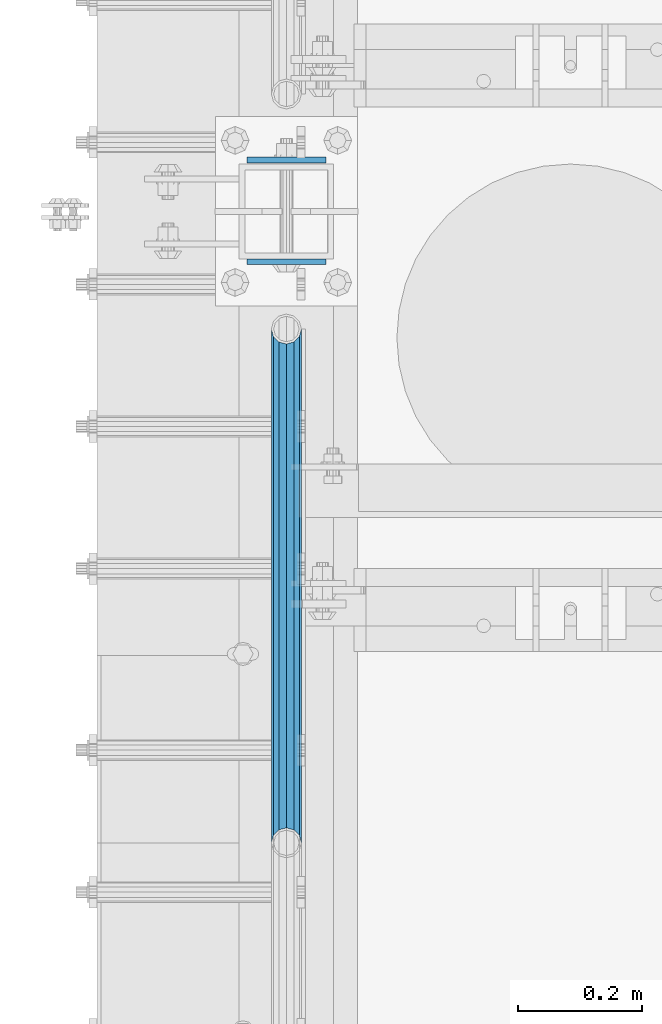
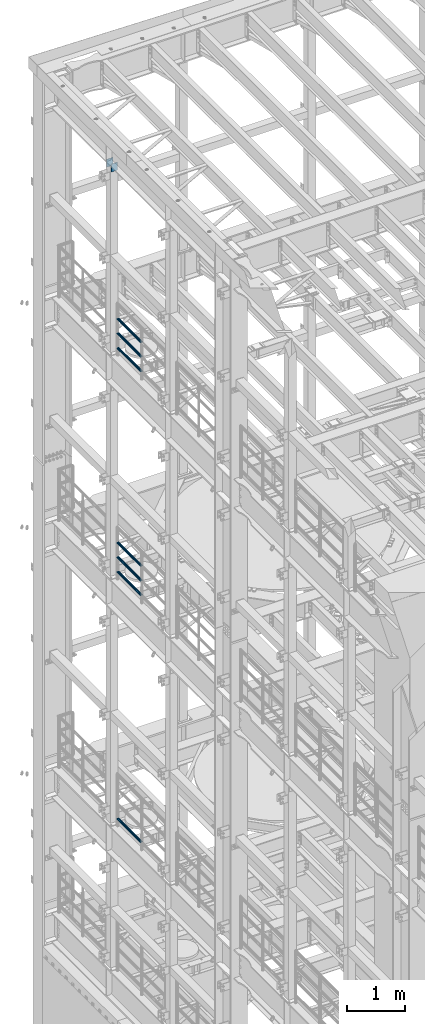
# One storey, part 1306 of 1876: 9 beams, 4 elements without a shape of their own.
"""IFC2X3 building model written with IfcOpenShell, lengths in millimetres."""

from ifc_helpers import new_model, si_unit, frame, origin_with_axes, place, context, subcontext, project, spatial, faceted_brep, material, type_object, element, aggregate, save


model = new_model("IFC2X3")

# Units and contexts
model_context = context("Model", 3, precision=1e-05, world=origin_with_axes())
body_context = subcontext(model_context, "Body", "Model", "MODEL_VIEW")
ifc_project = project(units=[si_unit("LENGTHUNIT", "METRE", prefix="MILLI"), si_unit("AREAUNIT", "SQUARE_METRE"), si_unit("VOLUMEUNIT", "CUBIC_METRE"), si_unit("MASSUNIT", "GRAM", prefix="KILO"), si_unit("TIMEUNIT", "SECOND"), si_unit("PLANEANGLEUNIT", "RADIAN"), si_unit("SOLIDANGLEUNIT", "STERADIAN"), si_unit("THERMODYNAMICTEMPERATUREUNIT", "DEGREE_CELSIUS"), si_unit("LUMINOUSINTENSITYUNIT", "LUMEN")], contexts=[model_context])

# Site, building, storey
site_placement = place(None, origin_with_axes())
site = spatial("IfcSite", under=ifc_project, at=site_placement, CompositionType="ELEMENT")
building_placement = place(site_placement, origin_with_axes())
building = spatial("IfcBuilding", under=site, at=building_placement, Name="Undefined", CompositionType="ELEMENT")
storey_placement = place(building_placement, origin_with_axes())
storey = spatial("IfcBuildingStorey", under=building, at=storey_placement, Name="Undefined", CompositionType="ELEMENT", Elevation=0.0)

# Assembly, beams
assembly_1_placement = place(storey_placement, origin_with_axes())
assembly_1 = element("IfcElementAssembly", 1, at=assembly_1_placement, inside=storey, Name="RAIL", AssemblyPlace="NOTDEFINED", PredefinedType="RIGID_FRAME")
ifc_material_1 = material()
beam_type_1 = type_object("IfcBeamType", Name="PIPE1-1/2SCH40", PredefinedType="NOTDEFINED")
beam_1_placement = place(assembly_1_placement, frame((-1.81898940354586e-12, 11494.77, 18145.125), z_axis=(0.0, 0.0, 1.0), x_axis=(0.0, -1.0, 0.0)))
beam_1 = element("IfcBeam", 2, at=beam_1_placement, type_object=beam_type_1, material=ifc_material_1, Name="RAIL", ObjectType="PIPE1-1/2SCH40", context=body_context, shape_type="Brep", body=[
    faceted_brep([(805.872807006681, -12.0649999999996, 20.8971929933177), (805.872807006683, -12.0649999999996, 15.8661214311796), (805.379378568819, -10.2235000000001, 17.7076214311819), (802.640000000001, 0.0, 20.4470000000001), (802.640000000001, 0.0, 24.130000000001), (805.379378568819, 10.2235000000001, 17.7076214311819), (805.872807006683, 12.0649999999996, 15.8661214311796), (805.872807006681, 12.0649999999996, 20.8971929933177), (826.77, 24.1300000000001, 0.0), (814.705, 20.8971929933186, 12.0649999999987), (814.705, 20.8971929933186, -12.0649999999987), (811.515428437862, 17.7076214311801, 10.2235000000001), (814.254807006682, 20.4470000000001, 0.0), (811.515428437862, 17.7076214311801, -10.2235000000001), (805.872807006683, 12.0649999999996, -15.8661214311796), (805.872807006681, 12.0649999999996, -20.8971929933177), (805.379378568819, 10.2235000000001, -17.7076214311819), (802.640000000001, 0.0, -20.4470000000001), (802.640000000001, 0.0, -24.130000000001), (805.872807006683, -12.0649999999996, -15.8661214311796), (805.872807006681, -12.0649999999996, -20.8971929933177), (805.379378568819, -10.2235000000001, -17.7076214311819), (826.77, -24.1300000000001, 0.0), (814.705, -20.8971929933186, -12.0649999999987), (814.705, -20.8971929933186, 12.0649999999987), (811.515428437862, -17.7076214311801, -10.2235000000001), (814.254807006682, -20.4470000000001, 0.0), (811.515428437862, -17.7076214311801, 10.2235000000001), (12.0650000000064, -20.8971929933177, -12.0649999999987), (20.8971929933249, -12.0650000000005, -20.8971929933177), (0.0, 24.1299999999992, 0.0), (12.0650000000064, 20.8971929933177, -12.0649999999987), (12.0650000000064, 20.8971929933177, 12.0649999999987), (20.8971929933249, 12.0650000000005, 20.8971929933177), (24.1300000000064, 0.0, 24.130000000001), (20.8971929933249, 12.0650000000005, -20.8971929933177), (24.1300000000063, 0.0, -24.130000000001), (24.1300000000063, 0.0, -20.4470000000001), (20.8971929933249, -12.0650000000005, -15.8661214311796), (21.3906214311868, -10.2235000000001, -17.7076214311819), (21.3906214311868, 10.2235000000001, -17.7076214311819), (20.8971929933249, 12.0650000000005, -15.8661214311796), (15.2545715621445, 17.7076214311801, -10.2235000000001), (12.5151929933249, 20.4470000000001, 0.0), (15.2545715621445, 17.7076214311801, 10.2235000000001), (20.8971929933249, 12.0650000000005, 15.8661214311796), (21.3906214311868, 10.2235000000001, 17.7076214311819), (24.1300000000064, 0.0, 20.4470000000001), (21.3906214311868, -10.2235000000001, 17.7076214311819), (20.8971929933249, -12.0650000000005, 15.8661214311796), (20.8971929933249, -12.0650000000005, 20.8971929933177), (12.0650000000064, -20.8971929933177, 12.0649999999987), (0.0, -24.1299999999992, 0.0), (15.2545715621445, -17.7076214311801, 10.2235000000001), (12.5151929933249, -20.4470000000001, 0.0), (15.2545715621445, -17.7076214311801, -10.2235000000001)], [[[0, 1, 2, 3, 4]], [[4, 3, 5, 6, 7]], [[8, 9, 10]], [[7, 6, 11, 12, 13, 14, 15, 10, 9]], [[16, 17, 18, 15, 14]], [[19, 20, 18, 17, 21]], [[22, 23, 24]], [[24, 23, 20, 19, 25, 26, 27, 1, 0]], [[28, 29, 20, 23]], [[30, 31, 32]], [[33, 34, 4, 7]], [[32, 33, 7, 9]], [[30, 32, 9, 8]], [[31, 30, 8, 10]], [[35, 31, 10, 15]], [[36, 35, 15, 18]], [[29, 36, 18, 20]], [[37, 36, 29, 38, 39]], [[40, 41, 35, 36, 37]], [[32, 31, 35, 41, 42, 43, 44, 45, 33]], [[33, 45, 46, 47, 34]], [[34, 47, 48, 49, 50]], [[34, 50, 0, 4]], [[50, 51, 24, 0]], [[51, 52, 22, 24]], [[52, 28, 23, 22]], [[51, 28, 52]], [[50, 49, 53, 54, 55, 38, 29, 28, 51]], [[55, 54, 26, 25]], [[21, 39, 38, 55, 25, 19]], [[37, 39, 21, 17]], [[40, 37, 17, 16]], [[42, 41, 40, 16, 14, 13]], [[43, 42, 13, 12]], [[44, 43, 12, 11]], [[5, 46, 45, 44, 11, 6]], [[47, 46, 5, 3]], [[48, 47, 3, 2]], [[53, 49, 48, 2, 1, 27]], [[54, 53, 27, 26]]]),
])
beam_2_placement = place(assembly_1_placement, frame((-1.81898940354586e-12, 10668.0, 18449.925), z_axis=(0.0, 0.0, -1.0), x_axis=(0.0, 1.0, 0.0)))
beam_2 = element("IfcBeam", 3, at=beam_2_placement, type_object=beam_type_1, material=ifc_material_1, Name="RAIL", ObjectType="PIPE1-1/2SCH40", context=body_context, shape_type="Brep", body=[
    faceted_brep([(0.0, 24.1299999999992, 0.0), (12.0650000000064, 20.8971929933177, -12.0649999999987), (12.0650000000064, 20.8971929933177, 12.0649999999987), (12.0650000000064, -20.8971929933177, 12.0649999999987), (12.0650000000064, -20.8971929933177, -12.0649999999987), (0.0, -24.1299999999992, 0.0), (20.8971929933249, -12.0650000000005, 20.8971929933177), (20.8971929933249, -12.0650000000005, 15.8661214311796), (15.2545715621445, -17.7076214311801, 10.2235000000001), (12.5151929933249, -20.4470000000001, 0.0), (15.2545715621445, -17.7076214311801, -10.2235000000001), (20.8971929933249, -12.0650000000005, -15.8661214311796), (20.8971929933249, -12.0650000000005, -20.8971929933177), (24.1300000000063, 0.0, -20.4470000000001), (24.1300000000063, 0.0, -24.130000000001), (21.3906214311868, -10.2235000000001, -17.7076214311819), (21.3906214311868, 10.2235000000001, -17.7076214311819), (20.8971929933249, 12.0650000000005, -15.8661214311796), (20.8971929933249, 12.0650000000005, -20.8971929933177), (15.2545715621445, 17.7076214311801, -10.2235000000001), (12.5151929933249, 20.4470000000001, 0.0), (15.2545715621445, 17.7076214311801, 10.2235000000001), (20.8971929933249, 12.0650000000005, 15.8661214311796), (20.8971929933249, 12.0650000000005, 20.8971929933177), (21.3906214311868, 10.2235000000001, 17.7076214311819), (24.1300000000064, 0.0, 20.4470000000001), (24.1300000000064, 0.0, 24.130000000001), (21.3906214311868, -10.2235000000001, 17.7076214311819), (826.77, 24.1300000000001, 0.0), (814.705, 20.8971929933186, -12.0649999999987), (805.872807006681, 12.0649999999996, -20.8971929933177), (826.77, -24.1300000000001, 0.0), (814.705, -20.8971929933186, -12.0649999999987), (814.705, -20.8971929933186, 12.0649999999987), (805.872807006681, -12.0649999999996, 20.8971929933177), (805.872807006681, -12.0649999999996, -20.8971929933177), (802.640000000001, 0.0, -24.130000000001), (805.379378568819, 10.2235000000001, -17.7076214311819), (802.640000000001, 0.0, -20.4470000000001), (805.872807006683, 12.0649999999996, -15.8661214311796), (805.872807006683, -12.0649999999996, -15.8661214311796), (805.379378568819, -10.2235000000001, -17.7076214311819), (811.515428437862, -17.7076214311801, -10.2235000000001), (814.254807006682, -20.4470000000001, 0.0), (811.515428437862, -17.7076214311801, 10.2235000000001), (805.872807006683, -12.0649999999996, 15.8661214311796), (805.379378568819, -10.2235000000001, 17.7076214311819), (802.640000000001, 0.0, 20.4470000000001), (802.640000000001, 0.0, 24.130000000001), (805.872807006681, 12.0649999999996, 20.8971929933177), (814.705, 20.8971929933186, 12.0649999999987), (805.872807006683, 12.0649999999996, 15.8661214311796), (811.515428437862, 17.7076214311801, 10.2235000000001), (814.254807006682, 20.4470000000001, 0.0), (811.515428437862, 17.7076214311801, -10.2235000000001), (805.379378568819, 10.2235000000001, 17.7076214311819)], [[[0, 1, 2]], [[3, 4, 5]], [[6, 7, 8, 9, 10, 11, 12, 4, 3]], [[13, 14, 12, 11, 15]], [[16, 17, 18, 14, 13]], [[2, 1, 18, 17, 19, 20, 21, 22, 23]], [[23, 22, 24, 25, 26]], [[26, 25, 27, 7, 6]], [[1, 0, 28, 29]], [[18, 1, 29, 30]], [[31, 32, 33]], [[6, 3, 33, 34]], [[3, 5, 31, 33]], [[5, 4, 32, 31]], [[4, 12, 35, 32]], [[12, 14, 36, 35]], [[14, 18, 30, 36]], [[37, 38, 36, 30, 39]], [[40, 35, 36, 38, 41]], [[33, 32, 35, 40, 42, 43, 44, 45, 34]], [[34, 45, 46, 47, 48]], [[26, 6, 34, 48]], [[2, 23, 49, 50]], [[23, 26, 48, 49]], [[0, 2, 50, 28]], [[28, 50, 29]], [[49, 51, 52, 53, 54, 39, 30, 29, 50]], [[48, 47, 55, 51, 49]], [[25, 24, 55, 47]], [[55, 24, 22, 21, 52, 51]], [[21, 20, 53, 52]], [[20, 19, 54, 53]], [[19, 17, 16, 37, 39, 54]], [[16, 13, 38, 37]], [[13, 15, 41, 38]], [[41, 15, 11, 10, 42, 40]], [[10, 9, 43, 42]], [[9, 8, 44, 43]], [[8, 7, 27, 46, 45, 44]], [[27, 25, 47, 46]]]),
])
beam_3_placement = place(assembly_1_placement, frame((-1.81898940354586e-12, 10668.0, 18754.725), z_axis=(0.0, 0.0, -1.0), x_axis=(0.0, 1.0, 0.0)))
beam_3 = element("IfcBeam", 4, at=beam_3_placement, type_object=beam_type_1, material=ifc_material_1, Name="RAIL", ObjectType="PIPE1-1/2SCH40", context=body_context, shape_type="Brep", body=[
    faceted_brep([(0.0, 24.1299999999992, 0.0), (12.0650000000064, 20.8971929933177, -12.0649999999987), (12.0650000000064, 20.8971929933177, 12.0649999999987), (12.0650000000064, -20.8971929933177, 12.0649999999987), (12.0650000000064, -20.8971929933177, -12.0649999999987), (0.0, -24.1299999999992, 0.0), (20.8971929933249, -12.0650000000005, 20.8971929933177), (20.8971929933249, -12.0650000000005, 15.8661214311796), (15.2545715621445, -17.7076214311801, 10.2235000000001), (12.5151929933249, -20.4470000000001, 0.0), (15.2545715621445, -17.7076214311801, -10.2235000000001), (20.8971929933249, -12.0650000000005, -15.8661214311796), (20.8971929933249, -12.0650000000005, -20.8971929933177), (24.1300000000063, 0.0, -20.4470000000001), (24.1300000000063, 0.0, -24.130000000001), (21.3906214311868, -10.2235000000001, -17.7076214311819), (21.3906214311868, 10.2235000000001, -17.7076214311819), (20.8971929933249, 12.0650000000005, -15.8661214311796), (20.8971929933249, 12.0650000000005, -20.8971929933177), (15.2545715621445, 17.7076214311801, -10.2235000000001), (12.5151929933249, 20.4470000000001, 0.0), (15.2545715621445, 17.7076214311801, 10.2235000000001), (20.8971929933249, 12.0650000000005, 15.8661214311796), (20.8971929933249, 12.0650000000005, 20.8971929933177), (21.3906214311868, 10.2235000000001, 17.7076214311819), (24.1300000000064, 0.0, 20.4470000000001), (24.1300000000064, 0.0, 24.130000000001), (21.3906214311868, -10.2235000000001, 17.7076214311819), (826.77, 24.1300000000001, 0.0), (814.705, 20.8971929933186, -12.0649999999987), (805.872807006681, 12.0649999999996, -20.8971929933177), (826.77, -24.1300000000001, 0.0), (814.705, -20.8971929933186, -12.0649999999987), (814.705, -20.8971929933186, 12.0649999999987), (805.872807006681, -12.0649999999996, 20.8971929933177), (805.872807006681, -12.0649999999996, -20.8971929933177), (802.640000000001, 0.0, -24.130000000001), (805.379378568819, 10.2235000000001, -17.7076214311819), (802.640000000001, 0.0, -20.4470000000001), (805.872807006683, 12.0649999999996, -15.8661214311796), (805.872807006683, -12.0649999999996, -15.8661214311796), (805.379378568819, -10.2235000000001, -17.7076214311819), (811.515428437862, -17.7076214311801, -10.2235000000001), (814.254807006682, -20.4470000000001, 0.0), (811.515428437862, -17.7076214311801, 10.2235000000001), (805.872807006683, -12.0649999999996, 15.8661214311796), (805.379378568819, -10.2235000000001, 17.7076214311819), (802.640000000001, 0.0, 20.4470000000001), (802.640000000001, 0.0, 24.130000000001), (805.872807006681, 12.0649999999996, 20.8971929933177), (814.705, 20.8971929933186, 12.0649999999987), (805.872807006683, 12.0649999999996, 15.8661214311796), (811.515428437862, 17.7076214311801, 10.2235000000001), (814.254807006682, 20.4470000000001, 0.0), (811.515428437862, 17.7076214311801, -10.2235000000001), (805.379378568819, 10.2235000000001, 17.7076214311819)], [[[0, 1, 2]], [[3, 4, 5]], [[6, 7, 8, 9, 10, 11, 12, 4, 3]], [[13, 14, 12, 11, 15]], [[16, 17, 18, 14, 13]], [[2, 1, 18, 17, 19, 20, 21, 22, 23]], [[23, 22, 24, 25, 26]], [[26, 25, 27, 7, 6]], [[1, 0, 28, 29]], [[18, 1, 29, 30]], [[31, 32, 33]], [[6, 3, 33, 34]], [[3, 5, 31, 33]], [[5, 4, 32, 31]], [[4, 12, 35, 32]], [[12, 14, 36, 35]], [[14, 18, 30, 36]], [[37, 38, 36, 30, 39]], [[40, 35, 36, 38, 41]], [[33, 32, 35, 40, 42, 43, 44, 45, 34]], [[34, 45, 46, 47, 48]], [[26, 6, 34, 48]], [[2, 23, 49, 50]], [[23, 26, 48, 49]], [[0, 2, 50, 28]], [[28, 50, 29]], [[49, 51, 52, 53, 54, 39, 30, 29, 50]], [[48, 47, 55, 51, 49]], [[25, 24, 55, 47]], [[55, 24, 22, 21, 52, 51]], [[21, 20, 53, 52]], [[20, 19, 54, 53]], [[19, 17, 16, 37, 39, 54]], [[16, 13, 38, 37]], [[13, 15, 41, 38]], [[41, 15, 11, 10, 42, 40]], [[10, 9, 43, 42]], [[9, 8, 44, 43]], [[8, 7, 27, 46, 45, 44]], [[27, 25, 47, 46]]]),
])
aggregate(assembly_1, [beam_1, beam_2, beam_3])

assembly_2_placement = place(storey_placement, origin_with_axes())
assembly_2 = element("IfcElementAssembly", 5, at=assembly_2_placement, inside=storey, Name="RAIL", AssemblyPlace="NOTDEFINED", PredefinedType="RIGID_FRAME")
beam_4_placement = place(assembly_2_placement, frame((-1.81898940354586e-12, 11494.77, 13471.525), z_axis=(0.0, 0.0, 1.0), x_axis=(0.0, -1.0, 0.0)))
beam_4 = element("IfcBeam", 6, at=beam_4_placement, type_object=beam_type_1, material=ifc_material_1, Name="RAIL", ObjectType="PIPE1-1/2SCH40", context=body_context, shape_type="Brep", body=[
    faceted_brep([(805.872807006681, -12.0649999999996, 20.8971929933177), (805.872807006683, -12.0649999999996, 15.8661214311796), (805.379378568819, -10.2235000000001, 17.7076214311819), (802.640000000001, 0.0, 20.4470000000001), (802.640000000001, 0.0, 24.130000000001), (805.379378568819, 10.2235000000001, 17.7076214311819), (805.872807006683, 12.0649999999996, 15.8661214311796), (805.872807006681, 12.0649999999996, 20.8971929933177), (826.77, 24.1300000000001, 0.0), (814.705, 20.8971929933186, 12.0649999999987), (814.705, 20.8971929933186, -12.0649999999987), (811.515428437862, 17.7076214311801, 10.2235000000001), (814.254807006682, 20.4470000000001, 0.0), (811.515428437862, 17.7076214311801, -10.2235000000001), (805.872807006683, 12.0649999999996, -15.8661214311796), (805.872807006681, 12.0649999999996, -20.8971929933177), (805.379378568819, 10.2235000000001, -17.7076214311819), (802.640000000001, 0.0, -20.4470000000001), (802.640000000001, 0.0, -24.130000000001), (805.872807006683, -12.0649999999996, -15.8661214311796), (805.872807006681, -12.0649999999996, -20.8971929933177), (805.379378568819, -10.2235000000001, -17.7076214311819), (826.77, -24.1300000000001, 0.0), (814.705, -20.8971929933186, -12.0649999999987), (814.705, -20.8971929933186, 12.0649999999987), (811.515428437862, -17.7076214311801, -10.2235000000001), (814.254807006682, -20.4470000000001, 0.0), (811.515428437862, -17.7076214311801, 10.2235000000001), (12.0650000000064, -20.8971929933177, -12.0649999999987), (20.8971929933249, -12.0650000000005, -20.8971929933177), (0.0, 24.1299999999992, 0.0), (12.0650000000064, 20.8971929933177, -12.0649999999987), (12.0650000000064, 20.8971929933177, 12.0649999999987), (20.8971929933249, 12.0650000000005, 20.8971929933177), (24.1300000000064, 0.0, 24.130000000001), (20.8971929933249, 12.0650000000005, -20.8971929933177), (24.1300000000063, 0.0, -24.130000000001), (24.1300000000063, 0.0, -20.4470000000001), (20.8971929933249, -12.0650000000005, -15.8661214311796), (21.3906214311868, -10.2235000000001, -17.7076214311819), (21.3906214311868, 10.2235000000001, -17.7076214311819), (20.8971929933249, 12.0650000000005, -15.8661214311796), (15.2545715621445, 17.7076214311801, -10.2235000000001), (12.5151929933249, 20.4470000000001, 0.0), (15.2545715621445, 17.7076214311801, 10.2235000000001), (20.8971929933249, 12.0650000000005, 15.8661214311796), (21.3906214311868, 10.2235000000001, 17.7076214311819), (24.1300000000064, 0.0, 20.4470000000001), (21.3906214311868, -10.2235000000001, 17.7076214311819), (20.8971929933249, -12.0650000000005, 15.8661214311796), (20.8971929933249, -12.0650000000005, 20.8971929933177), (12.0650000000064, -20.8971929933177, 12.0649999999987), (0.0, -24.1299999999992, 0.0), (15.2545715621445, -17.7076214311801, 10.2235000000001), (12.5151929933249, -20.4470000000001, 0.0), (15.2545715621445, -17.7076214311801, -10.2235000000001)], [[[0, 1, 2, 3, 4]], [[4, 3, 5, 6, 7]], [[8, 9, 10]], [[7, 6, 11, 12, 13, 14, 15, 10, 9]], [[16, 17, 18, 15, 14]], [[19, 20, 18, 17, 21]], [[22, 23, 24]], [[24, 23, 20, 19, 25, 26, 27, 1, 0]], [[28, 29, 20, 23]], [[30, 31, 32]], [[33, 34, 4, 7]], [[32, 33, 7, 9]], [[30, 32, 9, 8]], [[31, 30, 8, 10]], [[35, 31, 10, 15]], [[36, 35, 15, 18]], [[29, 36, 18, 20]], [[37, 36, 29, 38, 39]], [[40, 41, 35, 36, 37]], [[32, 31, 35, 41, 42, 43, 44, 45, 33]], [[33, 45, 46, 47, 34]], [[34, 47, 48, 49, 50]], [[34, 50, 0, 4]], [[50, 51, 24, 0]], [[51, 52, 22, 24]], [[52, 28, 23, 22]], [[51, 28, 52]], [[50, 49, 53, 54, 55, 38, 29, 28, 51]], [[55, 54, 26, 25]], [[21, 39, 38, 55, 25, 19]], [[37, 39, 21, 17]], [[40, 37, 17, 16]], [[42, 41, 40, 16, 14, 13]], [[43, 42, 13, 12]], [[44, 43, 12, 11]], [[5, 46, 45, 44, 11, 6]], [[47, 46, 5, 3]], [[48, 47, 3, 2]], [[53, 49, 48, 2, 1, 27]], [[54, 53, 27, 26]]]),
])
beam_5_placement = place(assembly_2_placement, frame((-1.81898940354586e-12, 10668.0, 13776.325), z_axis=(0.0, 0.0, -1.0), x_axis=(0.0, 1.0, 0.0)))
beam_5 = element("IfcBeam", 7, at=beam_5_placement, type_object=beam_type_1, material=ifc_material_1, Name="RAIL", ObjectType="PIPE1-1/2SCH40", context=body_context, shape_type="Brep", body=[
    faceted_brep([(0.0, 24.1299999999992, 0.0), (12.0650000000064, 20.8971929933177, -12.0649999999987), (12.0650000000064, 20.8971929933177, 12.0649999999987), (12.0650000000064, -20.8971929933177, 12.0649999999987), (12.0650000000064, -20.8971929933177, -12.0649999999987), (0.0, -24.1299999999992, 0.0), (20.8971929933249, -12.0650000000005, 20.8971929933177), (20.8971929933249, -12.0650000000005, 15.8661214311796), (15.2545715621445, -17.7076214311801, 10.2235000000001), (12.5151929933249, -20.4470000000001, 0.0), (15.2545715621445, -17.7076214311801, -10.2235000000001), (20.8971929933249, -12.0650000000005, -15.8661214311796), (20.8971929933249, -12.0650000000005, -20.8971929933177), (24.1300000000063, 0.0, -20.4470000000001), (24.1300000000063, 0.0, -24.130000000001), (21.3906214311868, -10.2235000000001, -17.7076214311819), (21.3906214311868, 10.2235000000001, -17.7076214311819), (20.8971929933249, 12.0650000000005, -15.8661214311796), (20.8971929933249, 12.0650000000005, -20.8971929933177), (15.2545715621445, 17.7076214311801, -10.2235000000001), (12.5151929933249, 20.4470000000001, 0.0), (15.2545715621445, 17.7076214311801, 10.2235000000001), (20.8971929933249, 12.0650000000005, 15.8661214311796), (20.8971929933249, 12.0650000000005, 20.8971929933177), (21.3906214311868, 10.2235000000001, 17.7076214311819), (24.1300000000064, 0.0, 20.4470000000001), (24.1300000000064, 0.0, 24.130000000001), (21.3906214311868, -10.2235000000001, 17.7076214311819), (826.77, 24.1300000000001, 0.0), (814.705, 20.8971929933186, -12.0649999999987), (805.872807006681, 12.0649999999996, -20.8971929933177), (826.77, -24.1300000000001, 0.0), (814.705, -20.8971929933186, -12.0649999999987), (814.705, -20.8971929933186, 12.0649999999987), (805.872807006681, -12.0649999999996, 20.8971929933177), (805.872807006681, -12.0649999999996, -20.8971929933177), (802.640000000001, 0.0, -24.130000000001), (805.379378568819, 10.2235000000001, -17.7076214311819), (802.640000000001, 0.0, -20.4470000000001), (805.872807006683, 12.0649999999996, -15.8661214311796), (805.872807006683, -12.0649999999996, -15.8661214311796), (805.379378568819, -10.2235000000001, -17.7076214311819), (811.515428437862, -17.7076214311801, -10.2235000000001), (814.254807006682, -20.4470000000001, 0.0), (811.515428437862, -17.7076214311801, 10.2235000000001), (805.872807006683, -12.0649999999996, 15.8661214311796), (805.379378568819, -10.2235000000001, 17.7076214311819), (802.640000000001, 0.0, 20.4470000000001), (802.640000000001, 0.0, 24.130000000001), (805.872807006681, 12.0649999999996, 20.8971929933177), (814.705, 20.8971929933186, 12.0649999999987), (805.872807006683, 12.0649999999996, 15.8661214311796), (811.515428437862, 17.7076214311801, 10.2235000000001), (814.254807006682, 20.4470000000001, 0.0), (811.515428437862, 17.7076214311801, -10.2235000000001), (805.379378568819, 10.2235000000001, 17.7076214311819)], [[[0, 1, 2]], [[3, 4, 5]], [[6, 7, 8, 9, 10, 11, 12, 4, 3]], [[13, 14, 12, 11, 15]], [[16, 17, 18, 14, 13]], [[2, 1, 18, 17, 19, 20, 21, 22, 23]], [[23, 22, 24, 25, 26]], [[26, 25, 27, 7, 6]], [[1, 0, 28, 29]], [[18, 1, 29, 30]], [[31, 32, 33]], [[6, 3, 33, 34]], [[3, 5, 31, 33]], [[5, 4, 32, 31]], [[4, 12, 35, 32]], [[12, 14, 36, 35]], [[14, 18, 30, 36]], [[37, 38, 36, 30, 39]], [[40, 35, 36, 38, 41]], [[33, 32, 35, 40, 42, 43, 44, 45, 34]], [[34, 45, 46, 47, 48]], [[26, 6, 34, 48]], [[2, 23, 49, 50]], [[23, 26, 48, 49]], [[0, 2, 50, 28]], [[28, 50, 29]], [[49, 51, 52, 53, 54, 39, 30, 29, 50]], [[48, 47, 55, 51, 49]], [[25, 24, 55, 47]], [[55, 24, 22, 21, 52, 51]], [[21, 20, 53, 52]], [[20, 19, 54, 53]], [[19, 17, 16, 37, 39, 54]], [[16, 13, 38, 37]], [[13, 15, 41, 38]], [[41, 15, 11, 10, 42, 40]], [[10, 9, 43, 42]], [[9, 8, 44, 43]], [[8, 7, 27, 46, 45, 44]], [[27, 25, 47, 46]]]),
])
beam_6_placement = place(assembly_2_placement, frame((-1.81898940354586e-12, 10668.0, 14081.125), z_axis=(0.0, 0.0, -1.0), x_axis=(0.0, 1.0, 0.0)))
beam_6 = element("IfcBeam", 8, at=beam_6_placement, type_object=beam_type_1, material=ifc_material_1, Name="RAIL", ObjectType="PIPE1-1/2SCH40", context=body_context, shape_type="Brep", body=[
    faceted_brep([(0.0, 24.1299999999992, 0.0), (12.0650000000064, 20.8971929933177, -12.0649999999987), (12.0650000000064, 20.8971929933177, 12.0649999999987), (12.0650000000064, -20.8971929933177, 12.0649999999987), (12.0650000000064, -20.8971929933177, -12.0649999999987), (0.0, -24.1299999999992, 0.0), (20.8971929933249, -12.0650000000005, 20.8971929933177), (20.8971929933249, -12.0650000000005, 15.8661214311796), (15.2545715621445, -17.7076214311801, 10.2235000000001), (12.5151929933249, -20.4470000000001, 0.0), (15.2545715621445, -17.7076214311801, -10.2235000000001), (20.8971929933249, -12.0650000000005, -15.8661214311796), (20.8971929933249, -12.0650000000005, -20.8971929933177), (24.1300000000063, 0.0, -20.4470000000001), (24.1300000000063, 0.0, -24.130000000001), (21.3906214311868, -10.2235000000001, -17.7076214311819), (21.3906214311868, 10.2235000000001, -17.7076214311819), (20.8971929933249, 12.0650000000005, -15.8661214311796), (20.8971929933249, 12.0650000000005, -20.8971929933177), (15.2545715621445, 17.7076214311801, -10.2235000000001), (12.5151929933249, 20.4470000000001, 0.0), (15.2545715621445, 17.7076214311801, 10.2235000000001), (20.8971929933249, 12.0650000000005, 15.8661214311796), (20.8971929933249, 12.0650000000005, 20.8971929933177), (21.3906214311868, 10.2235000000001, 17.7076214311819), (24.1300000000064, 0.0, 20.4470000000001), (24.1300000000064, 0.0, 24.130000000001), (21.3906214311868, -10.2235000000001, 17.7076214311819), (826.77, 24.1300000000001, 0.0), (814.705, 20.8971929933186, -12.0649999999987), (805.872807006681, 12.0649999999996, -20.8971929933177), (826.77, -24.1300000000001, 0.0), (814.705, -20.8971929933186, -12.0649999999987), (814.705, -20.8971929933186, 12.0649999999987), (805.872807006681, -12.0649999999996, 20.8971929933177), (805.872807006681, -12.0649999999996, -20.8971929933177), (802.640000000001, 0.0, -24.130000000001), (805.379378568819, 10.2235000000001, -17.7076214311819), (802.640000000001, 0.0, -20.4470000000001), (805.872807006683, 12.0649999999996, -15.8661214311796), (805.872807006683, -12.0649999999996, -15.8661214311796), (805.379378568819, -10.2235000000001, -17.7076214311819), (811.515428437862, -17.7076214311801, -10.2235000000001), (814.254807006682, -20.4470000000001, 0.0), (811.515428437862, -17.7076214311801, 10.2235000000001), (805.872807006683, -12.0649999999996, 15.8661214311796), (805.379378568819, -10.2235000000001, 17.7076214311819), (802.640000000001, 0.0, 20.4470000000001), (802.640000000001, 0.0, 24.130000000001), (805.872807006681, 12.0649999999996, 20.8971929933177), (814.705, 20.8971929933186, 12.0649999999987), (805.872807006683, 12.0649999999996, 15.8661214311796), (811.515428437862, 17.7076214311801, 10.2235000000001), (814.254807006682, 20.4470000000001, 0.0), (811.515428437862, 17.7076214311801, -10.2235000000001), (805.379378568819, 10.2235000000001, 17.7076214311819)], [[[0, 1, 2]], [[3, 4, 5]], [[6, 7, 8, 9, 10, 11, 12, 4, 3]], [[13, 14, 12, 11, 15]], [[16, 17, 18, 14, 13]], [[2, 1, 18, 17, 19, 20, 21, 22, 23]], [[23, 22, 24, 25, 26]], [[26, 25, 27, 7, 6]], [[1, 0, 28, 29]], [[18, 1, 29, 30]], [[31, 32, 33]], [[6, 3, 33, 34]], [[3, 5, 31, 33]], [[5, 4, 32, 31]], [[4, 12, 35, 32]], [[12, 14, 36, 35]], [[14, 18, 30, 36]], [[37, 38, 36, 30, 39]], [[40, 35, 36, 38, 41]], [[33, 32, 35, 40, 42, 43, 44, 45, 34]], [[34, 45, 46, 47, 48]], [[26, 6, 34, 48]], [[2, 23, 49, 50]], [[23, 26, 48, 49]], [[0, 2, 50, 28]], [[28, 50, 29]], [[49, 51, 52, 53, 54, 39, 30, 29, 50]], [[48, 47, 55, 51, 49]], [[25, 24, 55, 47]], [[55, 24, 22, 21, 52, 51]], [[21, 20, 53, 52]], [[20, 19, 54, 53]], [[19, 17, 16, 37, 39, 54]], [[16, 13, 38, 37]], [[13, 15, 41, 38]], [[41, 15, 11, 10, 42, 40]], [[10, 9, 43, 42]], [[9, 8, 44, 43]], [[8, 7, 27, 46, 45, 44]], [[27, 25, 47, 46]]]),
])
aggregate(assembly_2, [beam_4, beam_5, beam_6])

# Assembly, beam
assembly_3_placement = place(storey_placement, origin_with_axes())
assembly_3 = element("IfcElementAssembly", 9, at=assembly_3_placement, inside=storey, Name="RAIL", AssemblyPlace="NOTDEFINED", PredefinedType="RIGID_FRAME")
beam_7_placement = place(assembly_3_placement, frame((-1.81898940354586e-12, 11494.77, 8315.325), z_axis=(0.0, 0.0, 1.0), x_axis=(0.0, -1.0, 0.0)))
beam_7 = element("IfcBeam", 10, at=beam_7_placement, type_object=beam_type_1, material=ifc_material_1, Name="RAIL", ObjectType="PIPE1-1/2SCH40", context=body_context, shape_type="Brep", body=[
    faceted_brep([(805.872807006681, -12.0649999999996, 20.8971929933177), (805.872807006683, -12.0649999999996, 15.8661214311796), (805.379378568819, -10.2235000000001, 17.7076214311819), (802.640000000001, 0.0, 20.4470000000001), (802.640000000001, 0.0, 24.130000000001), (805.379378568819, 10.2235000000001, 17.7076214311819), (805.872807006683, 12.0649999999996, 15.8661214311796), (805.872807006681, 12.0649999999996, 20.8971929933177), (826.77, 24.1300000000001, 0.0), (814.705, 20.8971929933186, 12.0649999999987), (814.705, 20.8971929933186, -12.0649999999987), (811.515428437862, 17.7076214311801, 10.2235000000001), (814.254807006682, 20.4470000000001, 0.0), (811.515428437862, 17.7076214311801, -10.2235000000001), (805.872807006683, 12.0649999999996, -15.8661214311796), (805.872807006681, 12.0649999999996, -20.8971929933177), (805.379378568819, 10.2235000000001, -17.7076214311819), (802.640000000001, 0.0, -20.4470000000001), (802.640000000001, 0.0, -24.130000000001), (805.872807006683, -12.0649999999996, -15.8661214311796), (805.872807006681, -12.0649999999996, -20.8971929933177), (805.379378568819, -10.2235000000001, -17.7076214311819), (826.77, -24.1300000000001, 0.0), (814.705, -20.8971929933186, -12.0649999999987), (814.705, -20.8971929933186, 12.0649999999987), (811.515428437862, -17.7076214311801, -10.2235000000001), (814.254807006682, -20.4470000000001, 0.0), (811.515428437862, -17.7076214311801, 10.2235000000001), (12.0650000000064, -20.8971929933177, -12.0649999999987), (20.8971929933249, -12.0650000000005, -20.8971929933177), (0.0, 24.1299999999992, 0.0), (12.0650000000064, 20.8971929933177, -12.0649999999987), (12.0650000000064, 20.8971929933177, 12.0649999999987), (20.8971929933249, 12.0650000000005, 20.8971929933177), (24.1300000000064, 0.0, 24.130000000001), (20.8971929933249, 12.0650000000005, -20.8971929933177), (24.1300000000063, 0.0, -24.130000000001), (24.1300000000063, 0.0, -20.4470000000001), (20.8971929933249, -12.0650000000005, -15.8661214311796), (21.3906214311868, -10.2235000000001, -17.7076214311819), (21.3906214311868, 10.2235000000001, -17.7076214311819), (20.8971929933249, 12.0650000000005, -15.8661214311796), (15.2545715621445, 17.7076214311801, -10.2235000000001), (12.5151929933249, 20.4470000000001, 0.0), (15.2545715621445, 17.7076214311801, 10.2235000000001), (20.8971929933249, 12.0650000000005, 15.8661214311796), (21.3906214311868, 10.2235000000001, 17.7076214311819), (24.1300000000064, 0.0, 20.4470000000001), (21.3906214311868, -10.2235000000001, 17.7076214311819), (20.8971929933249, -12.0650000000005, 15.8661214311796), (20.8971929933249, -12.0650000000005, 20.8971929933177), (12.0650000000064, -20.8971929933177, 12.0649999999987), (0.0, -24.1299999999992, 0.0), (15.2545715621445, -17.7076214311801, 10.2235000000001), (12.5151929933249, -20.4470000000001, 0.0), (15.2545715621445, -17.7076214311801, -10.2235000000001)], [[[0, 1, 2, 3, 4]], [[4, 3, 5, 6, 7]], [[8, 9, 10]], [[7, 6, 11, 12, 13, 14, 15, 10, 9]], [[16, 17, 18, 15, 14]], [[19, 20, 18, 17, 21]], [[22, 23, 24]], [[24, 23, 20, 19, 25, 26, 27, 1, 0]], [[28, 29, 20, 23]], [[30, 31, 32]], [[33, 34, 4, 7]], [[32, 33, 7, 9]], [[30, 32, 9, 8]], [[31, 30, 8, 10]], [[35, 31, 10, 15]], [[36, 35, 15, 18]], [[29, 36, 18, 20]], [[37, 36, 29, 38, 39]], [[40, 41, 35, 36, 37]], [[32, 31, 35, 41, 42, 43, 44, 45, 33]], [[33, 45, 46, 47, 34]], [[34, 47, 48, 49, 50]], [[34, 50, 0, 4]], [[50, 51, 24, 0]], [[51, 52, 22, 24]], [[52, 28, 23, 22]], [[51, 28, 52]], [[50, 49, 53, 54, 55, 38, 29, 28, 51]], [[55, 54, 26, 25]], [[21, 39, 38, 55, 25, 19]], [[37, 39, 21, 17]], [[40, 37, 17, 16]], [[42, 41, 40, 16, 14, 13]], [[43, 42, 13, 12]], [[44, 43, 12, 11]], [[5, 46, 45, 44, 11, 6]], [[47, 46, 5, 3]], [[48, 47, 3, 2]], [[53, 49, 48, 2, 1, 27]], [[54, 53, 27, 26]]]),
])
aggregate(assembly_3, [beam_7])

# Assembly, beams
assembly_4_placement = place(storey_placement, origin_with_axes())
assembly_4 = element("IfcElementAssembly", 11, at=assembly_4_placement, inside=storey, Name="BEAM", AssemblyPlace="NOTDEFINED", PredefinedType="RIGID_FRAME")
ifc_material_2 = material(Name="STEEL/A36")
beam_type_2 = type_object("IfcBeamType", PredefinedType="NOTDEFINED")
beam_8_placement = place(assembly_4_placement, frame((-63.5, 11766.55, 21850.35), z_axis=(0.0, 0.0, -1.0), x_axis=(1.0, 0.0, 0.0)))
beam_8 = element("IfcBeam", 12, at=beam_8_placement, type_object=beam_type_2, material=ifc_material_2, Name="PLATE", context=body_context, shape_type="Brep", body=[
    faceted_brep([(0.0, 4.76249999999982, -82.5499999999993), (0.0, 4.76249999999982, 82.5499999999993), (127.0, 4.76249999999982, 82.5499999999993), (127.0, 4.76249999999982, -82.5499999999993), (0.0, -4.76249999999982, 82.5499999999993), (127.0, -4.76249999999982, 82.5499999999993), (0.0, -4.76249999999982, -82.5499999999993), (127.0, -4.76249999999982, -82.5499999999993)], [[[0, 1, 2, 3]], [[1, 4, 5, 2]], [[4, 6, 7, 5]], [[6, 0, 3, 7]], [[5, 7, 3, 2]], [[6, 4, 1, 0]]]),
])
beam_9_placement = place(assembly_4_placement, frame((-63.5, 11603.0375, 21850.35), z_axis=(0.0, 0.0, -1.0), x_axis=(1.0, 0.0, 0.0)))
beam_9 = element("IfcBeam", 13, at=beam_9_placement, type_object=beam_type_2, material=ifc_material_2, Name="PLATE", context=body_context, shape_type="Brep", body=[
    faceted_brep([(0.0, 4.76249999999982, -82.5499999999993), (0.0, 4.76249999999982, 82.5499999999993), (127.0, 4.76249999999982, 82.5499999999993), (127.0, 4.76249999999982, -82.5499999999993), (0.0, -4.76249999999982, 82.5499999999993), (127.0, -4.76249999999982, 82.5499999999993), (0.0, -4.76249999999982, -82.5499999999993), (127.0, -4.76249999999982, -82.5499999999993)], [[[0, 1, 2, 3]], [[1, 4, 5, 2]], [[4, 6, 7, 5]], [[6, 0, 3, 7]], [[5, 7, 3, 2]], [[6, 4, 1, 0]]]),
])
aggregate(assembly_4, [beam_8, beam_9])

save(model, "model.ifc")
